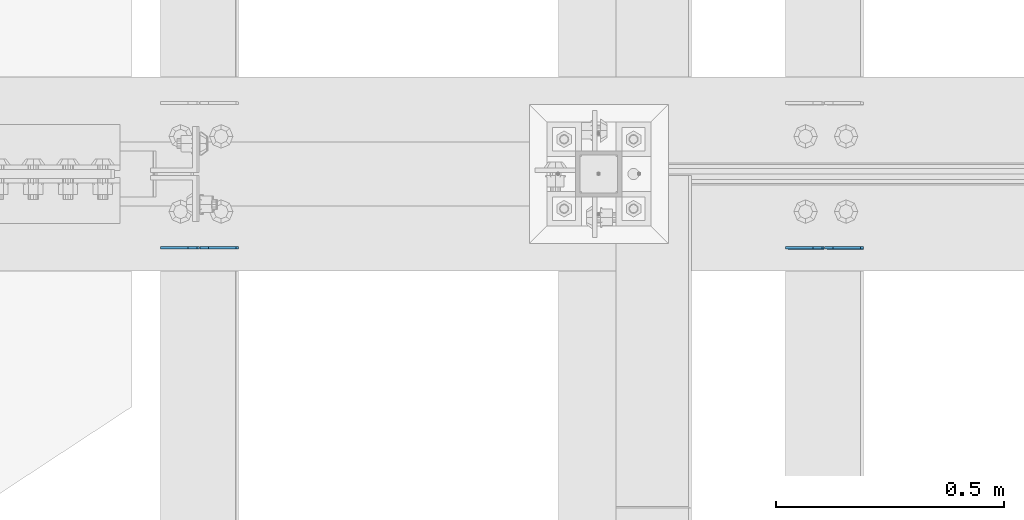
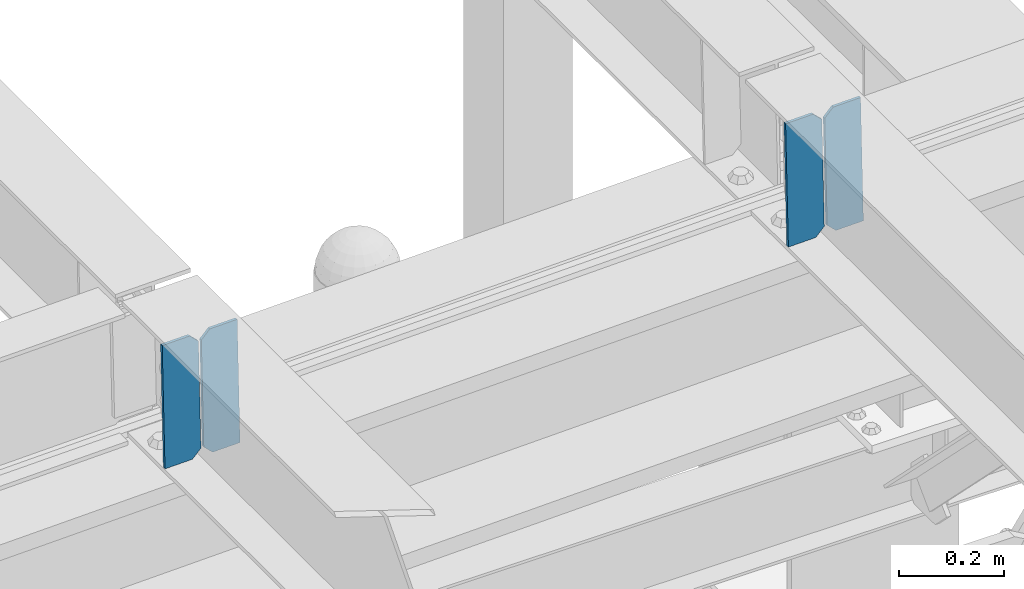
# One storey, part 3370 of 3843: 4 plates, 2 elements without a shape of their own.
"""IFC2X3 building model written with IfcOpenShell, lengths in millimetres."""

from ifc_helpers import new_model, si_unit, frame, origin_with_axes, place, context, subcontext, project, spatial, faceted_brep, material, type_object, element, aggregate, save


model = new_model("IFC2X3")

# Units and contexts
model_context = context("Model", 3, precision=1e-05, world=origin_with_axes())
body_context = subcontext(model_context, "Body", "Model", "MODEL_VIEW")
ifc_project = project(units=[si_unit("LENGTHUNIT", "METRE", prefix="MILLI"), si_unit("AREAUNIT", "SQUARE_METRE"), si_unit("VOLUMEUNIT", "CUBIC_METRE"), si_unit("MASSUNIT", "GRAM", prefix="KILO"), si_unit("TIMEUNIT", "SECOND"), si_unit("PLANEANGLEUNIT", "RADIAN"), si_unit("SOLIDANGLEUNIT", "STERADIAN"), si_unit("THERMODYNAMICTEMPERATUREUNIT", "DEGREE_CELSIUS"), si_unit("LUMINOUSINTENSITYUNIT", "LUMEN")], contexts=[model_context])

# Site, building, storey
site_placement = place(None, origin_with_axes())
site = spatial("IfcSite", under=ifc_project, at=site_placement, CompositionType="ELEMENT")
building_placement = place(site_placement, origin_with_axes())
building = spatial("IfcBuilding", under=site, at=building_placement, Name="Undefined", CompositionType="ELEMENT")
storey_placement = place(building_placement, origin_with_axes())
storey = spatial("IfcBuildingStorey", under=building, at=storey_placement, Name="Undefined", CompositionType="ELEMENT", Elevation=0.0)

# Assembly, plates
assembly_1_placement = place(storey_placement, origin_with_axes())
assembly_1 = element("IfcElementAssembly", 1, at=assembly_1_placement, inside=storey, Name="BEAM", AssemblyPlace="NOTDEFINED", PredefinedType="RIGID_FRAME")
ifc_material = material(Name="STEEL/A572-50")
plate_type = type_object("IfcPlateType", PredefinedType="NOTDEFINED")
plate_1_placement = place(assembly_1_placement, frame((39401.4964783243, 75466.4922967842, 45503.0089866513), z_axis=(-0.0211520978211338, 0.00027729799997178, 0.999776230895486), x_axis=(-0.999776269348334, -6.33400000515396e-06, -0.0211520970073616)))
plate_1 = element("IfcPlate", 2, at=plate_1_placement, type_object=plate_type, material=ifc_material, Name="PLATE", context=body_context, shape_type="Brep", body=[
    faceted_brep([(0.0, -3.17499999999927, 0.0), (6.83940015733242e-10, -3.17499999996653, 288.924999998613), (6.54836185276508e-10, 3.17500000001746, 288.924999998591), (0.0, 3.17499999999927, 0.0), (60.3250007643655, -3.17500000017753, 288.924999998606), (60.3250007643219, 3.17499999979918, 288.924999998584), (79.3750000013097, -3.17500000025029, 269.875000761494), (79.375000001266, 3.17499999972642, 269.875000761487), (79.375000000713, -3.17500000026484, 19.0499992370605), (79.3750000006985, 3.17499999971187, 19.0499992370533), (60.325000763667, -3.17500000020664, -1.45519152283669e-11), (60.3250007636234, 3.17499999977736, -3.63797880709171e-11)], [[[0, 1, 2, 3]], [[1, 4, 5, 2]], [[4, 6, 7, 5]], [[6, 8, 9, 7]], [[8, 10, 11, 9]], [[10, 0, 3, 11]], [[5, 7, 9, 11, 3, 2]], [[10, 8, 6, 4, 1, 0]]]),
])
plate_2_placement = place(assembly_1_placement, frame((39315.790657635, 75466.4917938567, 45501.1957231203), z_axis=(-0.0211520978211338, 0.00027729799997178, 0.999776230895486), x_axis=(-0.999776269348334, -6.33400000515396e-06, -0.0211520970073616)))
plate_2 = element("IfcPlate", 3, at=plate_2_placement, type_object=plate_type, material=ifc_material, Name="PLATE", context=body_context, shape_type="Brep", body=[
    faceted_brep([(4.36557456851006e-11, -3.17499999998836, 19.0499992370969), (6.11180439591408e-10, -3.17499999996653, 269.875000761516), (5.96628524363041e-10, 3.17500000001746, 269.875000761502), (1.45519152283669e-11, 3.17499999998836, 19.0499992370824), (19.0499992376572, -3.17500000003201, 288.924999998606), (19.0499992376281, 3.1749999999447, 288.924999998584), (79.3750000013242, -3.17500000025029, 288.924999998591), (79.3750000013097, 3.1749999997337, 288.92499999857), (79.3750000006548, -3.17500000026484, -2.18278728425503e-11), (79.3750000006403, 3.17499999969732, -2.91038304567337e-11), (19.0499992370023, -3.17500000005384, 0.0), (19.0499992369587, 3.17499999992287, -1.45519152283669e-11)], [[[0, 1, 2, 3]], [[1, 4, 5, 2]], [[4, 6, 7, 5]], [[6, 8, 9, 7]], [[8, 10, 11, 9]], [[10, 0, 3, 11]], [[5, 7, 9, 11, 3, 2]], [[10, 8, 6, 4, 1, 0]]]),
])
aggregate(assembly_1, [plate_1, plate_2])

assembly_2_placement = place(storey_placement, origin_with_axes())
assembly_2 = element("IfcElementAssembly", 4, at=assembly_2_placement, inside=storey, Name="BEAM", AssemblyPlace="NOTDEFINED", PredefinedType="RIGID_FRAME")
plate_3_placement = place(assembly_2_placement, frame((38029.8964783231, 75466.5330032031, 45467.2800249466), z_axis=(-0.0211520982170187, 0.000140802000052645, 0.999776259427985), x_axis=(-0.999776269342228, -3.16699999781408e-06, -0.0211520980072162)))
plate_3 = element("IfcPlate", 5, at=plate_3_placement, type_object=plate_type, material=ifc_material, Name="PLATE", context=body_context, shape_type="Brep", body=[
    faceted_brep([(0.0, -3.17499999999927, 0.0), (6.83940015733242e-10, -3.17499999996653, 288.924999998613), (6.54836185276508e-10, 3.17500000001746, 288.924999998591), (0.0, 3.17499999999927, 0.0), (60.3250007643655, -3.17500000017753, 288.924999998606), (60.3250007643219, 3.17499999979918, 288.924999998584), (79.3750000013097, -3.17500000025029, 269.875000761494), (79.375000001266, 3.17499999972642, 269.875000761487), (79.375000000713, -3.17500000026484, 19.0499992370605), (79.3750000006985, 3.17499999971187, 19.0499992370533), (60.325000763667, -3.17500000020664, -1.45519152283669e-11), (60.3250007636234, 3.17499999977736, -3.63797880709171e-11)], [[[0, 1, 2, 3]], [[1, 4, 5, 2]], [[4, 6, 7, 5]], [[6, 8, 9, 7]], [[8, 10, 11, 9]], [[10, 0, 3, 11]], [[5, 7, 9, 11, 3, 2]], [[10, 8, 6, 4, 1, 0]]]),
])
plate_4_placement = place(assembly_2_placement, frame((37944.1906576338, 75466.5327478351, 45465.4667613631), z_axis=(-0.0211520982170187, 0.000140802000052645, 0.999776259427985), x_axis=(-0.999776269342228, -3.16699999781408e-06, -0.0211520980072162)))
plate_4 = element("IfcPlate", 6, at=plate_4_placement, type_object=plate_type, material=ifc_material, Name="PLATE", context=body_context, shape_type="Brep", body=[
    faceted_brep([(4.36557456851006e-11, -3.17499999998836, 19.0499992370969), (6.11180439591408e-10, -3.17499999996653, 269.875000761516), (5.96628524363041e-10, 3.17500000001746, 269.875000761502), (1.45519152283669e-11, 3.17499999998836, 19.0499992370824), (19.0499992376572, -3.17500000003201, 288.924999998606), (19.0499992376281, 3.1749999999447, 288.924999998584), (79.3750000013242, -3.17500000025029, 288.924999998591), (79.3750000013097, 3.1749999997337, 288.92499999857), (79.3750000006548, -3.17500000026484, -2.18278728425503e-11), (79.3750000006403, 3.17499999969732, -2.91038304567337e-11), (19.0499992370023, -3.17500000005384, 0.0), (19.0499992369587, 3.17499999992287, -1.45519152283669e-11)], [[[0, 1, 2, 3]], [[1, 4, 5, 2]], [[4, 6, 7, 5]], [[6, 8, 9, 7]], [[8, 10, 11, 9]], [[10, 0, 3, 11]], [[5, 7, 9, 11, 3, 2]], [[10, 8, 6, 4, 1, 0]]]),
])
aggregate(assembly_2, [plate_3, plate_4])

save(model, "model.ifc")
